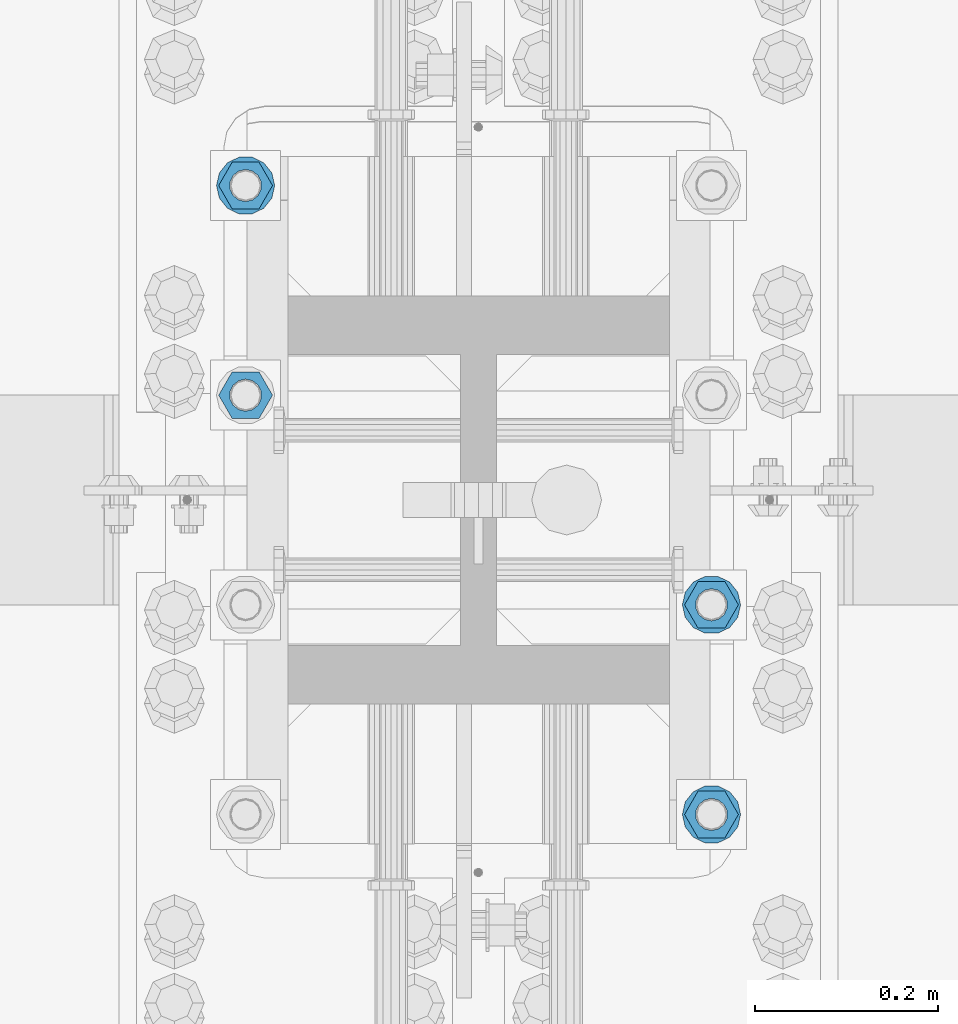
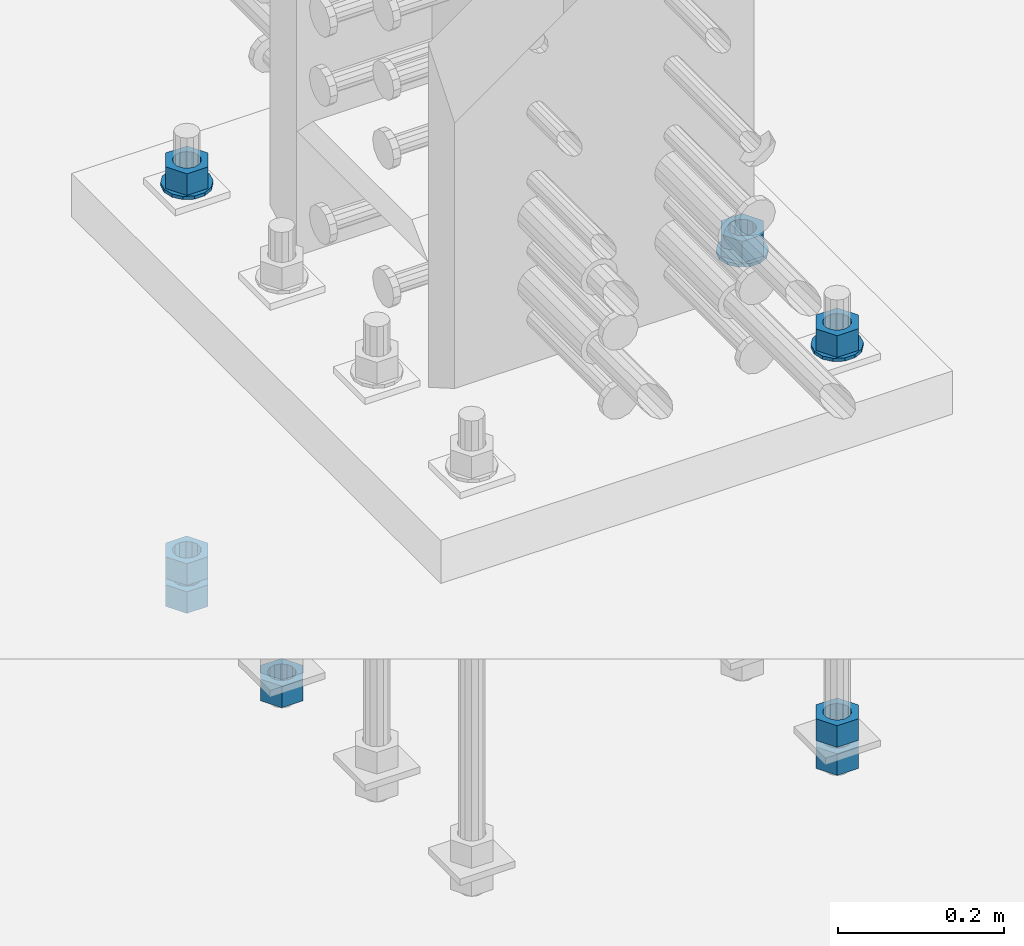
# One storey, part 1011 of 1763: 11 columns, 1 element without a shape of its own.
"""IFC2X3 building model written with IfcOpenShell, lengths in millimetres."""

from ifc_helpers import new_model, si_unit, frame, origin_with_axes, place, context, subcontext, project, spatial, faceted_brep, material, type_object, element, aggregate, save


model = new_model("IFC2X3")

# Units and contexts
model_context = context("Model", 3, precision=1e-05, world=origin_with_axes())
body_context = subcontext(model_context, "Body", "Model", "MODEL_VIEW")
ifc_project = project(units=[si_unit("LENGTHUNIT", "METRE", prefix="MILLI"), si_unit("AREAUNIT", "SQUARE_METRE"), si_unit("VOLUMEUNIT", "CUBIC_METRE"), si_unit("MASSUNIT", "GRAM", prefix="KILO"), si_unit("TIMEUNIT", "SECOND"), si_unit("PLANEANGLEUNIT", "RADIAN"), si_unit("SOLIDANGLEUNIT", "STERADIAN"), si_unit("THERMODYNAMICTEMPERATUREUNIT", "DEGREE_CELSIUS"), si_unit("LUMINOUSINTENSITYUNIT", "LUMEN")], contexts=[model_context])

# Site, building, storey
site_placement = place(None, origin_with_axes())
site = spatial("IfcSite", under=ifc_project, at=site_placement, CompositionType="ELEMENT")
building_placement = place(site_placement, origin_with_axes())
building = spatial("IfcBuilding", under=site, at=building_placement, Name="Undefined", CompositionType="ELEMENT")
storey_placement = place(building_placement, origin_with_axes())
storey = spatial("IfcBuildingStorey", under=building, at=storey_placement, Name="Undefined", CompositionType="ELEMENT", Elevation=0.0)

# Assembly, columns
assembly_placement = place(storey_placement, origin_with_axes())
assembly = element("IfcElementAssembly", 1, at=assembly_placement, inside=storey, Name="TEMPLATE", AssemblyPlace="NOTDEFINED", PredefinedType="RIGID_FRAME")
ifc_material_1 = material(Name="STEEL/A563")
column_type_1 = type_object("IfcColumnType", Name="1-1/4_HEAVY_HEX_NUT", PredefinedType="NOTDEFINED")
column_1_placement = place(assembly_placement, frame((-23773.8372736984, 114.299999999998, 3957.6375), z_axis=(0.0, 1.0, 0.0), x_axis=(0.0, 0.0, -1.0)))
column_1 = element("IfcColumn", 2, at=column_1_placement, type_object=column_type_1, material=ifc_material_1, Name="NUT", ObjectType="1-1/4_HEAVY_HEX_NUT", context=body_context, shape_type="Brep", body=[
    faceted_brep([(0.0, -29.3700008392334, 0.0), (0.0, -14.6800003051758, -25.4300003051758), (31.75, -14.6800003051758, -25.4300003051758), (31.75, -29.3700008392334, 0.0), (0.0, 14.6800003051758, -25.4300003051758), (31.75, 14.6800003051758, -25.4300003051758), (0.0, 29.3700008392334, 0.0), (31.75, 29.3700008392334, 0.0), (0.0, 14.6800003051758, 25.4300003051758), (31.75, 14.6800003051758, 25.4300003051758), (0.0, -14.6800003051758, 25.4300003051758), (31.75, -14.6800003051758, 25.4300003051758), (0.0, 0.0, 17.4599990844727), (0.0, 7.57560968776022, 15.730915608714), (31.75, 7.57560968775942, 15.7309156087145), (31.75, 0.0, 17.4599990844727), (0.0, 13.6507769681037, 10.8861313696252), (31.75, 13.6507769681048, 10.8861313696314), (0.0, 17.0222404541215, 3.88521530314756), (31.75, 17.02224045412, 3.88521530315316), (0.0, 17.0222404541215, -3.88521530314756), (31.75, 17.02224045412, -3.88521530315332), (0.0, 13.6507769681037, -10.8861313696252), (31.75, 13.6507769681048, -10.8861313696316), (0.0, 7.57560968776022, -15.730915608714), (31.75, 7.57560968775942, -15.7309156087146), (0.0, 0.0, -17.4599990844727), (31.75, 0.0, -17.4599990844727), (0.0, -7.57560968776022, -15.730915608714), (31.75, -7.57560968775942, -15.7309156087145), (0.0, -13.6507769681037, -10.8861313696252), (31.75, -13.6507769681048, -10.8861313696314), (0.0, -17.0222404541215, -3.88521530314756), (31.75, -17.02224045412, -3.88521530315316), (0.0, -17.0222404541215, 3.88521530314756), (31.75, -17.02224045412, 3.88521530315332), (0.0, -13.6507769681037, 10.8861313696252), (31.75, -13.6507769681048, 10.8861313696316), (0.0, -7.57560968776022, 15.730915608714), (31.75, -7.57560968775942, 15.7309156087146)], [[[0, 1, 2, 3]], [[1, 4, 5, 2]], [[4, 6, 7, 5]], [[6, 8, 9, 7]], [[8, 10, 11, 9]], [[10, 0, 3, 11]], [[12, 13, 14, 15]], [[13, 16, 17, 14]], [[16, 18, 19, 17]], [[18, 20, 21, 19]], [[20, 22, 23, 21]], [[22, 24, 25, 23]], [[24, 26, 27, 25]], [[26, 28, 29, 27]], [[28, 30, 31, 29]], [[30, 32, 33, 31]], [[32, 34, 35, 33]], [[34, 36, 37, 35]], [[36, 38, 39, 37]], [[38, 12, 15, 39]], [[5, 7, 9, 11, 3, 2], [17, 19, 21, 23, 25, 27, 29, 31, 33, 35, 37, 39, 15, 14]], [[10, 8, 6, 4, 1, 0], [38, 36, 34, 32, 30, 28, 26, 24, 22, 20, 18, 16, 13, 12]]]),
])
column_2_placement = place(assembly_placement, frame((-23773.8372736984, 114.299999999998, 3384.55), z_axis=(0.0, 1.0, 0.0), x_axis=(0.0, 0.0, -1.0)))
column_2 = element("IfcColumn", 3, at=column_2_placement, type_object=column_type_1, material=ifc_material_1, Name="NUT", ObjectType="1-1/4_HEAVY_HEX_NUT", context=body_context, shape_type="Brep", body=[
    faceted_brep([(0.0, -29.3700008392334, 0.0), (0.0, -14.6800003051758, -25.4300003051758), (31.75, -14.6800003051758, -25.4300003051758), (31.75, -29.3700008392334, 0.0), (0.0, 14.6800003051758, -25.4300003051758), (31.75, 14.6800003051758, -25.4300003051758), (0.0, 29.3700008392334, 0.0), (31.75, 29.3700008392334, 0.0), (0.0, 14.6800003051758, 25.4300003051758), (31.75, 14.6800003051758, 25.4300003051758), (0.0, -14.6800003051758, 25.4300003051758), (31.75, -14.6800003051758, 25.4300003051758), (0.0, 0.0, 17.4599990844727), (0.0, 7.57560968776022, 15.730915608714), (31.75, 7.57560968775942, 15.7309156087145), (31.75, 0.0, 17.4599990844727), (0.0, 13.6507769681037, 10.8861313696252), (31.75, 13.6507769681048, 10.8861313696314), (0.0, 17.0222404541215, 3.88521530314756), (31.75, 17.02224045412, 3.88521530315316), (0.0, 17.0222404541215, -3.88521530314756), (31.75, 17.02224045412, -3.88521530315332), (0.0, 13.6507769681037, -10.8861313696252), (31.75, 13.6507769681048, -10.8861313696316), (0.0, 7.57560968776022, -15.730915608714), (31.75, 7.57560968775942, -15.7309156087146), (0.0, 0.0, -17.4599990844727), (31.75, 0.0, -17.4599990844727), (0.0, -7.57560968776022, -15.730915608714), (31.75, -7.57560968775942, -15.7309156087145), (0.0, -13.6507769681037, -10.8861313696252), (31.75, -13.6507769681048, -10.8861313696314), (0.0, -17.0222404541215, -3.88521530314756), (31.75, -17.02224045412, -3.88521530315316), (0.0, -17.0222404541215, 3.88521530314756), (31.75, -17.02224045412, 3.88521530315332), (0.0, -13.6507769681037, 10.8861313696252), (31.75, -13.6507769681048, 10.8861313696316), (0.0, -7.57560968776022, 15.730915608714), (31.75, -7.57560968775942, 15.7309156087146)], [[[0, 1, 2, 3]], [[1, 4, 5, 2]], [[4, 6, 7, 5]], [[6, 8, 9, 7]], [[8, 10, 11, 9]], [[10, 0, 3, 11]], [[12, 13, 14, 15]], [[13, 16, 17, 14]], [[16, 18, 19, 17]], [[18, 20, 21, 19]], [[20, 22, 23, 21]], [[22, 24, 25, 23]], [[24, 26, 27, 25]], [[26, 28, 29, 27]], [[28, 30, 31, 29]], [[30, 32, 33, 31]], [[32, 34, 35, 33]], [[34, 36, 37, 35]], [[36, 38, 39, 37]], [[38, 12, 15, 39]], [[5, 7, 9, 11, 3, 2], [17, 19, 21, 23, 25, 27, 29, 31, 33, 35, 37, 39, 15, 14]], [[10, 8, 6, 4, 1, 0], [38, 36, 34, 32, 30, 28, 26, 24, 22, 20, 18, 16, 13, 12]]]),
])
column_3_placement = place(assembly_placement, frame((-23773.8372736984, 114.299999999998, 3343.275), z_axis=(0.0, 1.0, 0.0), x_axis=(0.0, 0.0, -1.0)))
column_3 = element("IfcColumn", 4, at=column_3_placement, type_object=column_type_1, material=ifc_material_1, Name="NUT", ObjectType="1-1/4_HEAVY_HEX_NUT", context=body_context, shape_type="Brep", body=[
    faceted_brep([(0.0, -29.3700008392334, 0.0), (0.0, -14.6800003051758, -25.4300003051758), (31.75, -14.6800003051758, -25.4300003051758), (31.75, -29.3700008392334, 0.0), (0.0, 14.6800003051758, -25.4300003051758), (31.75, 14.6800003051758, -25.4300003051758), (0.0, 29.3700008392334, 0.0), (31.75, 29.3700008392334, 0.0), (0.0, 14.6800003051758, 25.4300003051758), (31.75, 14.6800003051758, 25.4300003051758), (0.0, -14.6800003051758, 25.4300003051758), (31.75, -14.6800003051758, 25.4300003051758), (0.0, 0.0, 17.4599990844727), (0.0, 7.57560968776022, 15.730915608714), (31.75, 7.57560968775942, 15.7309156087145), (31.75, 0.0, 17.4599990844727), (0.0, 13.6507769681037, 10.8861313696252), (31.75, 13.6507769681048, 10.8861313696314), (0.0, 17.0222404541215, 3.88521530314756), (31.75, 17.02224045412, 3.88521530315316), (0.0, 17.0222404541215, -3.88521530314756), (31.75, 17.02224045412, -3.88521530315332), (0.0, 13.6507769681037, -10.8861313696252), (31.75, 13.6507769681048, -10.8861313696316), (0.0, 7.57560968776022, -15.730915608714), (31.75, 7.57560968775942, -15.7309156087146), (0.0, 0.0, -17.4599990844727), (31.75, 0.0, -17.4599990844727), (0.0, -7.57560968776022, -15.730915608714), (31.75, -7.57560968775942, -15.7309156087145), (0.0, -13.6507769681037, -10.8861313696252), (31.75, -13.6507769681048, -10.8861313696314), (0.0, -17.0222404541215, -3.88521530314756), (31.75, -17.02224045412, -3.88521530315316), (0.0, -17.0222404541215, 3.88521530314756), (31.75, -17.02224045412, 3.88521530315332), (0.0, -13.6507769681037, 10.8861313696252), (31.75, -13.6507769681048, 10.8861313696316), (0.0, -7.57560968776022, 15.730915608714), (31.75, -7.57560968775942, 15.7309156087146)], [[[0, 1, 2, 3]], [[1, 4, 5, 2]], [[4, 6, 7, 5]], [[6, 8, 9, 7]], [[8, 10, 11, 9]], [[10, 0, 3, 11]], [[12, 13, 14, 15]], [[13, 16, 17, 14]], [[16, 18, 19, 17]], [[18, 20, 21, 19]], [[20, 22, 23, 21]], [[22, 24, 25, 23]], [[24, 26, 27, 25]], [[26, 28, 29, 27]], [[28, 30, 31, 29]], [[30, 32, 33, 31]], [[32, 34, 35, 33]], [[34, 36, 37, 35]], [[36, 38, 39, 37]], [[38, 12, 15, 39]], [[5, 7, 9, 11, 3, 2], [17, 19, 21, 23, 25, 27, 29, 31, 33, 35, 37, 39, 15, 14]], [[10, 8, 6, 4, 1, 0], [38, 36, 34, 32, 30, 28, 26, 24, 22, 20, 18, 16, 13, 12]]]),
])
column_4_placement = place(assembly_placement, frame((-23773.8372736984, 342.899999999998, 3957.6375), z_axis=(0.0, 1.0, 0.0), x_axis=(0.0, 0.0, -1.0)))
column_4 = element("IfcColumn", 5, at=column_4_placement, type_object=column_type_1, material=ifc_material_1, Name="NUT", ObjectType="1-1/4_HEAVY_HEX_NUT", context=body_context, shape_type="Brep", body=[
    faceted_brep([(0.0, -29.3700008392334, 0.0), (0.0, -14.6800003051758, -25.4300003051758), (31.75, -14.6800003051758, -25.4300003051758), (31.75, -29.3700008392334, 0.0), (0.0, 14.6800003051758, -25.4300003051758), (31.75, 14.6800003051758, -25.4300003051758), (0.0, 29.3700008392334, 0.0), (31.75, 29.3700008392334, 0.0), (0.0, 14.6800003051758, 25.4300003051758), (31.75, 14.6800003051758, 25.4300003051758), (0.0, -14.6800003051758, 25.4300003051758), (31.75, -14.6800003051758, 25.4300003051758), (0.0, 0.0, 17.4599990844727), (0.0, 7.57560968776022, 15.730915608714), (31.75, 7.57560968775942, 15.7309156087145), (31.75, 0.0, 17.4599990844727), (0.0, 13.6507769681037, 10.8861313696252), (31.75, 13.6507769681048, 10.8861313696314), (0.0, 17.0222404541215, 3.88521530314756), (31.75, 17.02224045412, 3.88521530315316), (0.0, 17.0222404541215, -3.88521530314756), (31.75, 17.02224045412, -3.88521530315332), (0.0, 13.6507769681037, -10.8861313696252), (31.75, 13.6507769681048, -10.8861313696316), (0.0, 7.57560968776022, -15.730915608714), (31.75, 7.57560968775942, -15.7309156087146), (0.0, 0.0, -17.4599990844727), (31.75, 0.0, -17.4599990844727), (0.0, -7.57560968776022, -15.730915608714), (31.75, -7.57560968775942, -15.7309156087145), (0.0, -13.6507769681037, -10.8861313696252), (31.75, -13.6507769681048, -10.8861313696314), (0.0, -17.0222404541215, -3.88521530314756), (31.75, -17.02224045412, -3.88521530315316), (0.0, -17.0222404541215, 3.88521530314756), (31.75, -17.02224045412, 3.88521530315332), (0.0, -13.6507769681037, 10.8861313696252), (31.75, -13.6507769681048, 10.8861313696316), (0.0, -7.57560968776022, 15.730915608714), (31.75, -7.57560968775942, 15.7309156087146)], [[[0, 1, 2, 3]], [[1, 4, 5, 2]], [[4, 6, 7, 5]], [[6, 8, 9, 7]], [[8, 10, 11, 9]], [[10, 0, 3, 11]], [[12, 13, 14, 15]], [[13, 16, 17, 14]], [[16, 18, 19, 17]], [[18, 20, 21, 19]], [[20, 22, 23, 21]], [[22, 24, 25, 23]], [[24, 26, 27, 25]], [[26, 28, 29, 27]], [[28, 30, 31, 29]], [[30, 32, 33, 31]], [[32, 34, 35, 33]], [[34, 36, 37, 35]], [[36, 38, 39, 37]], [[38, 12, 15, 39]], [[5, 7, 9, 11, 3, 2], [17, 19, 21, 23, 25, 27, 29, 31, 33, 35, 37, 39, 15, 14]], [[10, 8, 6, 4, 1, 0], [38, 36, 34, 32, 30, 28, 26, 24, 22, 20, 18, 16, 13, 12]]]),
])
column_5_placement = place(assembly_placement, frame((-24281.8372736984, 571.499999999998, 3343.275), z_axis=(0.0, -1.0, 0.0), x_axis=(0.0, 0.0, -1.0)))
column_5 = element("IfcColumn", 6, at=column_5_placement, type_object=column_type_1, material=ifc_material_1, Name="NUT", ObjectType="1-1/4_HEAVY_HEX_NUT", context=body_context, shape_type="Brep", body=[
    faceted_brep([(0.0, -29.3700008392334, 0.0), (0.0, -14.6800003051758, -25.4300003051758), (31.75, -14.6800003051758, -25.4300003051758), (31.75, -29.3700008392334, 0.0), (0.0, 14.6800003051758, -25.4300003051758), (31.75, 14.6800003051758, -25.4300003051758), (0.0, 29.3700008392334, 0.0), (31.75, 29.3700008392334, 0.0), (0.0, 14.6800003051758, 25.4300003051758), (31.75, 14.6800003051758, 25.4300003051758), (0.0, -14.6800003051758, 25.4300003051758), (31.75, -14.6800003051758, 25.4300003051758), (0.0, 0.0, 17.4599990844727), (0.0, 7.57560968776022, 15.730915608714), (31.75, 7.57560968775942, 15.7309156087145), (31.75, 0.0, 17.4599990844727), (0.0, 13.6507769681037, 10.8861313696252), (31.75, 13.6507769681048, 10.8861313696314), (0.0, 17.0222404541215, 3.88521530314756), (31.75, 17.02224045412, 3.88521530315316), (0.0, 17.0222404541215, -3.88521530314756), (31.75, 17.02224045412, -3.88521530315332), (0.0, 13.6507769681037, -10.8861313696252), (31.75, 13.6507769681048, -10.8861313696316), (0.0, 7.57560968776022, -15.730915608714), (31.75, 7.57560968775942, -15.7309156087146), (0.0, 0.0, -17.4599990844727), (31.75, 0.0, -17.4599990844727), (0.0, -7.57560968776022, -15.730915608714), (31.75, -7.57560968775942, -15.7309156087145), (0.0, -13.6507769681037, -10.8861313696252), (31.75, -13.6507769681048, -10.8861313696314), (0.0, -17.0222404541215, -3.88521530314756), (31.75, -17.02224045412, -3.88521530315316), (0.0, -17.0222404541215, 3.88521530314756), (31.75, -17.02224045412, 3.88521530315332), (0.0, -13.6507769681037, 10.8861313696252), (31.75, -13.6507769681048, 10.8861313696316), (0.0, -7.57560968776022, 15.730915608714), (31.75, -7.57560968775942, 15.7309156087146)], [[[0, 1, 2, 3]], [[1, 4, 5, 2]], [[4, 6, 7, 5]], [[6, 8, 9, 7]], [[8, 10, 11, 9]], [[10, 0, 3, 11]], [[12, 13, 14, 15]], [[13, 16, 17, 14]], [[16, 18, 19, 17]], [[18, 20, 21, 19]], [[20, 22, 23, 21]], [[22, 24, 25, 23]], [[24, 26, 27, 25]], [[26, 28, 29, 27]], [[28, 30, 31, 29]], [[30, 32, 33, 31]], [[32, 34, 35, 33]], [[34, 36, 37, 35]], [[36, 38, 39, 37]], [[38, 12, 15, 39]], [[5, 7, 9, 11, 3, 2], [17, 19, 21, 23, 25, 27, 29, 31, 33, 35, 37, 39, 15, 14]], [[10, 8, 6, 4, 1, 0], [38, 36, 34, 32, 30, 28, 26, 24, 22, 20, 18, 16, 13, 12]]]),
])
column_6_placement = place(assembly_placement, frame((-24281.8372736984, 800.099999999998, 3957.6375), z_axis=(0.0, -1.0, 0.0), x_axis=(0.0, 0.0, -1.0)))
column_6 = element("IfcColumn", 7, at=column_6_placement, type_object=column_type_1, material=ifc_material_1, Name="NUT", ObjectType="1-1/4_HEAVY_HEX_NUT", context=body_context, shape_type="Brep", body=[
    faceted_brep([(0.0, -29.3700008392334, 0.0), (0.0, -14.6800003051758, -25.4300003051758), (31.75, -14.6800003051758, -25.4300003051758), (31.75, -29.3700008392334, 0.0), (0.0, 14.6800003051758, -25.4300003051758), (31.75, 14.6800003051758, -25.4300003051758), (0.0, 29.3700008392334, 0.0), (31.75, 29.3700008392334, 0.0), (0.0, 14.6800003051758, 25.4300003051758), (31.75, 14.6800003051758, 25.4300003051758), (0.0, -14.6800003051758, 25.4300003051758), (31.75, -14.6800003051758, 25.4300003051758), (0.0, 0.0, 17.4599990844727), (0.0, 7.57560968776022, 15.730915608714), (31.75, 7.57560968775942, 15.7309156087145), (31.75, 0.0, 17.4599990844727), (0.0, 13.6507769681037, 10.8861313696252), (31.75, 13.6507769681048, 10.8861313696314), (0.0, 17.0222404541215, 3.88521530314756), (31.75, 17.02224045412, 3.88521530315316), (0.0, 17.0222404541215, -3.88521530314756), (31.75, 17.02224045412, -3.88521530315332), (0.0, 13.6507769681037, -10.8861313696252), (31.75, 13.6507769681048, -10.8861313696316), (0.0, 7.57560968776022, -15.730915608714), (31.75, 7.57560968775942, -15.7309156087146), (0.0, 0.0, -17.4599990844727), (31.75, 0.0, -17.4599990844727), (0.0, -7.57560968776022, -15.730915608714), (31.75, -7.57560968775942, -15.7309156087145), (0.0, -13.6507769681037, -10.8861313696252), (31.75, -13.6507769681048, -10.8861313696314), (0.0, -17.0222404541215, -3.88521530314756), (31.75, -17.02224045412, -3.88521530315316), (0.0, -17.0222404541215, 3.88521530314756), (31.75, -17.02224045412, 3.88521530315332), (0.0, -13.6507769681037, 10.8861313696252), (31.75, -13.6507769681048, 10.8861313696316), (0.0, -7.57560968776022, 15.730915608714), (31.75, -7.57560968775942, 15.7309156087146)], [[[0, 1, 2, 3]], [[1, 4, 5, 2]], [[4, 6, 7, 5]], [[6, 8, 9, 7]], [[8, 10, 11, 9]], [[10, 0, 3, 11]], [[12, 13, 14, 15]], [[13, 16, 17, 14]], [[16, 18, 19, 17]], [[18, 20, 21, 19]], [[20, 22, 23, 21]], [[22, 24, 25, 23]], [[24, 26, 27, 25]], [[26, 28, 29, 27]], [[28, 30, 31, 29]], [[30, 32, 33, 31]], [[32, 34, 35, 33]], [[34, 36, 37, 35]], [[36, 38, 39, 37]], [[38, 12, 15, 39]], [[5, 7, 9, 11, 3, 2], [17, 19, 21, 23, 25, 27, 29, 31, 33, 35, 37, 39, 15, 14]], [[10, 8, 6, 4, 1, 0], [38, 36, 34, 32, 30, 28, 26, 24, 22, 20, 18, 16, 13, 12]]]),
])
column_7_placement = place(assembly_placement, frame((-24281.8372736984, 800.099999999998, 3384.55), z_axis=(0.0, -1.0, 0.0), x_axis=(0.0, 0.0, -1.0)))
column_7 = element("IfcColumn", 8, at=column_7_placement, type_object=column_type_1, material=ifc_material_1, Name="NUT", ObjectType="1-1/4_HEAVY_HEX_NUT", context=body_context, shape_type="Brep", body=[
    faceted_brep([(0.0, -29.3700008392334, 0.0), (0.0, -14.6800003051758, -25.4300003051758), (31.75, -14.6800003051758, -25.4300003051758), (31.75, -29.3700008392334, 0.0), (0.0, 14.6800003051758, -25.4300003051758), (31.75, 14.6800003051758, -25.4300003051758), (0.0, 29.3700008392334, 0.0), (31.75, 29.3700008392334, 0.0), (0.0, 14.6800003051758, 25.4300003051758), (31.75, 14.6800003051758, 25.4300003051758), (0.0, -14.6800003051758, 25.4300003051758), (31.75, -14.6800003051758, 25.4300003051758), (0.0, 0.0, 17.4599990844727), (0.0, 7.57560968776022, 15.730915608714), (31.75, 7.57560968775942, 15.7309156087145), (31.75, 0.0, 17.4599990844727), (0.0, 13.6507769681037, 10.8861313696252), (31.75, 13.6507769681048, 10.8861313696314), (0.0, 17.0222404541215, 3.88521530314756), (31.75, 17.02224045412, 3.88521530315316), (0.0, 17.0222404541215, -3.88521530314756), (31.75, 17.02224045412, -3.88521530315332), (0.0, 13.6507769681037, -10.8861313696252), (31.75, 13.6507769681048, -10.8861313696316), (0.0, 7.57560968776022, -15.730915608714), (31.75, 7.57560968775942, -15.7309156087146), (0.0, 0.0, -17.4599990844727), (31.75, 0.0, -17.4599990844727), (0.0, -7.57560968776022, -15.730915608714), (31.75, -7.57560968775942, -15.7309156087145), (0.0, -13.6507769681037, -10.8861313696252), (31.75, -13.6507769681048, -10.8861313696314), (0.0, -17.0222404541215, -3.88521530314756), (31.75, -17.02224045412, -3.88521530315316), (0.0, -17.0222404541215, 3.88521530314756), (31.75, -17.02224045412, 3.88521530315332), (0.0, -13.6507769681037, 10.8861313696252), (31.75, -13.6507769681048, 10.8861313696316), (0.0, -7.57560968776022, 15.730915608714), (31.75, -7.57560968775942, 15.7309156087146)], [[[0, 1, 2, 3]], [[1, 4, 5, 2]], [[4, 6, 7, 5]], [[6, 8, 9, 7]], [[8, 10, 11, 9]], [[10, 0, 3, 11]], [[12, 13, 14, 15]], [[13, 16, 17, 14]], [[16, 18, 19, 17]], [[18, 20, 21, 19]], [[20, 22, 23, 21]], [[22, 24, 25, 23]], [[24, 26, 27, 25]], [[26, 28, 29, 27]], [[28, 30, 31, 29]], [[30, 32, 33, 31]], [[32, 34, 35, 33]], [[34, 36, 37, 35]], [[36, 38, 39, 37]], [[38, 12, 15, 39]], [[5, 7, 9, 11, 3, 2], [17, 19, 21, 23, 25, 27, 29, 31, 33, 35, 37, 39, 15, 14]], [[10, 8, 6, 4, 1, 0], [38, 36, 34, 32, 30, 28, 26, 24, 22, 20, 18, 16, 13, 12]]]),
])
column_8_placement = place(assembly_placement, frame((-24281.8372736984, 800.099999999998, 3343.275), z_axis=(0.0, -1.0, 0.0), x_axis=(0.0, 0.0, -1.0)))
column_8 = element("IfcColumn", 9, at=column_8_placement, type_object=column_type_1, material=ifc_material_1, Name="NUT", ObjectType="1-1/4_HEAVY_HEX_NUT", context=body_context, shape_type="Brep", body=[
    faceted_brep([(0.0, -29.3700008392334, 0.0), (0.0, -14.6800003051758, -25.4300003051758), (31.75, -14.6800003051758, -25.4300003051758), (31.75, -29.3700008392334, 0.0), (0.0, 14.6800003051758, -25.4300003051758), (31.75, 14.6800003051758, -25.4300003051758), (0.0, 29.3700008392334, 0.0), (31.75, 29.3700008392334, 0.0), (0.0, 14.6800003051758, 25.4300003051758), (31.75, 14.6800003051758, 25.4300003051758), (0.0, -14.6800003051758, 25.4300003051758), (31.75, -14.6800003051758, 25.4300003051758), (0.0, 0.0, 17.4599990844727), (0.0, 7.57560968776022, 15.730915608714), (31.75, 7.57560968775942, 15.7309156087145), (31.75, 0.0, 17.4599990844727), (0.0, 13.6507769681037, 10.8861313696252), (31.75, 13.6507769681048, 10.8861313696314), (0.0, 17.0222404541215, 3.88521530314756), (31.75, 17.02224045412, 3.88521530315316), (0.0, 17.0222404541215, -3.88521530314756), (31.75, 17.02224045412, -3.88521530315332), (0.0, 13.6507769681037, -10.8861313696252), (31.75, 13.6507769681048, -10.8861313696316), (0.0, 7.57560968776022, -15.730915608714), (31.75, 7.57560968775942, -15.7309156087146), (0.0, 0.0, -17.4599990844727), (31.75, 0.0, -17.4599990844727), (0.0, -7.57560968776022, -15.730915608714), (31.75, -7.57560968775942, -15.7309156087145), (0.0, -13.6507769681037, -10.8861313696252), (31.75, -13.6507769681048, -10.8861313696314), (0.0, -17.0222404541215, -3.88521530314756), (31.75, -17.02224045412, -3.88521530315316), (0.0, -17.0222404541215, 3.88521530314756), (31.75, -17.02224045412, 3.88521530315332), (0.0, -13.6507769681037, 10.8861313696252), (31.75, -13.6507769681048, 10.8861313696316), (0.0, -7.57560968776022, 15.730915608714), (31.75, -7.57560968775942, 15.7309156087146)], [[[0, 1, 2, 3]], [[1, 4, 5, 2]], [[4, 6, 7, 5]], [[6, 8, 9, 7]], [[8, 10, 11, 9]], [[10, 0, 3, 11]], [[12, 13, 14, 15]], [[13, 16, 17, 14]], [[16, 18, 19, 17]], [[18, 20, 21, 19]], [[20, 22, 23, 21]], [[22, 24, 25, 23]], [[24, 26, 27, 25]], [[26, 28, 29, 27]], [[28, 30, 31, 29]], [[30, 32, 33, 31]], [[32, 34, 35, 33]], [[34, 36, 37, 35]], [[36, 38, 39, 37]], [[38, 12, 15, 39]], [[5, 7, 9, 11, 3, 2], [17, 19, 21, 23, 25, 27, 29, 31, 33, 35, 37, 39, 15, 14]], [[10, 8, 6, 4, 1, 0], [38, 36, 34, 32, 30, 28, 26, 24, 22, 20, 18, 16, 13, 12]]]),
])
ifc_material_2 = material(Name="STEEL/F436")
column_type_2 = type_object("IfcColumnType", Name="1-1/4_WASHER", PredefinedType="NOTDEFINED")
column_9_placement = place(assembly_placement, frame((-23773.8372736984, 114.299999999998, 3925.8875), z_axis=(0.0, 1.0, 0.0), x_axis=(0.0, 0.0, -1.0)))
column_9 = element("IfcColumn", 10, at=column_9_placement, type_object=column_type_2, material=ifc_material_2, Name="WASHER", ObjectType="1-1/4_WASHER", context=body_context, shape_type="Brep", body=[
    faceted_brep([(-4.54747350886464e-13, -31.7499999999964, 0.0), (0.0, -28.6057615559002, -13.7758087169827), (4.76249999999982, -28.6057615559002, -13.7758087169827), (4.76249999999982, -31.75, 0.0), (0.0, -19.795801209013, -24.8231495683602), (4.76249999999982, -19.795801209013, -24.8231495683602), (0.0, -7.06503965311276, -30.9539612117732), (4.76249999999982, -7.06503965311276, -30.9539612117732), (0.0, 7.06503965311276, -30.9539612117732), (4.76249999999982, 7.06503965311276, -30.9539612117732), (0.0, 19.7958012090166, -24.8231495683602), (4.76249999999982, 19.7958012090166, -24.8231495683602), (0.0, 28.6057615559039, -13.7758087169827), (4.76249999999982, 28.6057615559039, -13.7758087169827), (-5.91171556152403e-12, 31.7499999999891, 0.0), (4.76249999999982, 31.75, 0.0), (0.0, 28.6057615559002, 13.7758087169827), (4.76249999999982, 28.6057615559002, 13.7758087169827), (0.0, 19.795801209013, 24.8231495683602), (4.76249999999982, 19.795801209013, 24.8231495683602), (0.0, 7.06503965311276, 30.9539612117731), (4.76249999999982, 7.06503965311276, 30.9539612117731), (0.0, -7.06503965311276, 30.9539612117731), (4.76249999999982, -7.06503965311276, 30.9539612117731), (0.0, -19.7958012090166, 24.8231495683602), (4.76249999999982, -19.7958012090166, 24.8231495683602), (0.0, -28.6057615559039, 13.7758087169827), (4.76249999999982, -28.6057615559039, 13.7758087169827), (0.0, 0.0, 17.4599990844727), (0.0, 7.57560968776022, 15.730915608714), (4.76249999999982, 7.57560968775942, 15.7309156087145), (4.76249999999982, 0.0, 17.4599990844727), (0.0, 13.6507769681037, 10.8861313696252), (4.76249999999982, 13.6507769681048, 10.8861313696314), (0.0, 17.0222404541215, 3.88521530314756), (4.76249999999982, 17.02224045412, 3.88521530315316), (0.0, 17.0222404541215, -3.88521530314756), (4.76249999999982, 17.02224045412, -3.88521530315332), (0.0, 13.6507769681037, -10.8861313696252), (4.76249999999982, 13.6507769681048, -10.8861313696316), (0.0, 7.57560968776022, -15.730915608714), (4.76249999999982, 7.57560968775942, -15.7309156087146), (0.0, 0.0, -17.4599990844727), (4.76249999999982, 0.0, -17.4599990844727), (0.0, -7.57560968776022, -15.730915608714), (4.76249999999982, -7.57560968775942, -15.7309156087145), (0.0, -13.6507769681037, -10.8861313696252), (4.76249999999982, -13.6507769681048, -10.8861313696314), (0.0, -17.0222404541215, -3.88521530314756), (4.76249999999982, -17.02224045412, -3.88521530315316), (0.0, -17.0222404541215, 3.88521530314756), (4.76249999999982, -17.02224045412, 3.88521530315332), (0.0, -13.6507769681037, 10.8861313696252), (4.76249999999982, -13.6507769681048, 10.8861313696316), (0.0, -7.57560968776022, 15.730915608714), (4.76249999999982, -7.57560968775942, 15.7309156087146)], [[[0, 1, 2, 3]], [[1, 4, 5, 2]], [[4, 6, 7, 5]], [[6, 8, 9, 7]], [[8, 10, 11, 9]], [[10, 12, 13, 11]], [[12, 14, 15, 13]], [[14, 16, 17, 15]], [[16, 18, 19, 17]], [[18, 20, 21, 19]], [[20, 22, 23, 21]], [[22, 24, 25, 23]], [[24, 26, 27, 25]], [[26, 0, 3, 27]], [[28, 29, 30, 31]], [[29, 32, 33, 30]], [[32, 34, 35, 33]], [[34, 36, 37, 35]], [[36, 38, 39, 37]], [[38, 40, 41, 39]], [[40, 42, 43, 41]], [[42, 44, 45, 43]], [[44, 46, 47, 45]], [[46, 48, 49, 47]], [[48, 50, 51, 49]], [[50, 52, 53, 51]], [[52, 54, 55, 53]], [[54, 28, 31, 55]], [[5, 7, 9, 11, 13, 15, 17, 19, 21, 23, 25, 27, 3, 2], [33, 35, 37, 39, 41, 43, 45, 47, 49, 51, 53, 55, 31, 30]], [[26, 24, 22, 20, 18, 16, 14, 12, 10, 8, 6, 4, 1, 0], [54, 52, 50, 48, 46, 44, 42, 40, 38, 36, 34, 32, 29, 28]]]),
])
column_10_placement = place(assembly_placement, frame((-23773.8372736984, 342.899999999998, 3925.8875), z_axis=(0.0, 1.0, 0.0), x_axis=(0.0, 0.0, -1.0)))
column_10 = element("IfcColumn", 11, at=column_10_placement, type_object=column_type_2, material=ifc_material_2, Name="WASHER", ObjectType="1-1/4_WASHER", context=body_context, shape_type="Brep", body=[
    faceted_brep([(-4.54747350886464e-13, -31.7499999999964, 0.0), (0.0, -28.6057615559002, -13.7758087169827), (4.76249999999982, -28.6057615559002, -13.7758087169827), (4.76249999999982, -31.75, 0.0), (0.0, -19.795801209013, -24.8231495683602), (4.76249999999982, -19.795801209013, -24.8231495683602), (0.0, -7.06503965311276, -30.9539612117732), (4.76249999999982, -7.06503965311276, -30.9539612117732), (0.0, 7.06503965311276, -30.9539612117732), (4.76249999999982, 7.06503965311276, -30.9539612117732), (0.0, 19.7958012090166, -24.8231495683602), (4.76249999999982, 19.7958012090166, -24.8231495683602), (0.0, 28.6057615559039, -13.7758087169827), (4.76249999999982, 28.6057615559039, -13.7758087169827), (-5.91171556152403e-12, 31.7499999999891, 0.0), (4.76249999999982, 31.75, 0.0), (0.0, 28.6057615559002, 13.7758087169827), (4.76249999999982, 28.6057615559002, 13.7758087169827), (0.0, 19.795801209013, 24.8231495683602), (4.76249999999982, 19.795801209013, 24.8231495683602), (0.0, 7.06503965311276, 30.9539612117731), (4.76249999999982, 7.06503965311276, 30.9539612117731), (0.0, -7.06503965311276, 30.9539612117731), (4.76249999999982, -7.06503965311276, 30.9539612117731), (0.0, -19.7958012090166, 24.8231495683602), (4.76249999999982, -19.7958012090166, 24.8231495683602), (0.0, -28.6057615559039, 13.7758087169827), (4.76249999999982, -28.6057615559039, 13.7758087169827), (0.0, 0.0, 17.4599990844727), (0.0, 7.57560968776022, 15.730915608714), (4.76249999999982, 7.57560968775942, 15.7309156087145), (4.76249999999982, 0.0, 17.4599990844727), (0.0, 13.6507769681037, 10.8861313696252), (4.76249999999982, 13.6507769681048, 10.8861313696314), (0.0, 17.0222404541215, 3.88521530314756), (4.76249999999982, 17.02224045412, 3.88521530315316), (0.0, 17.0222404541215, -3.88521530314756), (4.76249999999982, 17.02224045412, -3.88521530315332), (0.0, 13.6507769681037, -10.8861313696252), (4.76249999999982, 13.6507769681048, -10.8861313696316), (0.0, 7.57560968776022, -15.730915608714), (4.76249999999982, 7.57560968775942, -15.7309156087146), (0.0, 0.0, -17.4599990844727), (4.76249999999982, 0.0, -17.4599990844727), (0.0, -7.57560968776022, -15.730915608714), (4.76249999999982, -7.57560968775942, -15.7309156087145), (0.0, -13.6507769681037, -10.8861313696252), (4.76249999999982, -13.6507769681048, -10.8861313696314), (0.0, -17.0222404541215, -3.88521530314756), (4.76249999999982, -17.02224045412, -3.88521530315316), (0.0, -17.0222404541215, 3.88521530314756), (4.76249999999982, -17.02224045412, 3.88521530315332), (0.0, -13.6507769681037, 10.8861313696252), (4.76249999999982, -13.6507769681048, 10.8861313696316), (0.0, -7.57560968776022, 15.730915608714), (4.76249999999982, -7.57560968775942, 15.7309156087146)], [[[0, 1, 2, 3]], [[1, 4, 5, 2]], [[4, 6, 7, 5]], [[6, 8, 9, 7]], [[8, 10, 11, 9]], [[10, 12, 13, 11]], [[12, 14, 15, 13]], [[14, 16, 17, 15]], [[16, 18, 19, 17]], [[18, 20, 21, 19]], [[20, 22, 23, 21]], [[22, 24, 25, 23]], [[24, 26, 27, 25]], [[26, 0, 3, 27]], [[28, 29, 30, 31]], [[29, 32, 33, 30]], [[32, 34, 35, 33]], [[34, 36, 37, 35]], [[36, 38, 39, 37]], [[38, 40, 41, 39]], [[40, 42, 43, 41]], [[42, 44, 45, 43]], [[44, 46, 47, 45]], [[46, 48, 49, 47]], [[48, 50, 51, 49]], [[50, 52, 53, 51]], [[52, 54, 55, 53]], [[54, 28, 31, 55]], [[5, 7, 9, 11, 13, 15, 17, 19, 21, 23, 25, 27, 3, 2], [33, 35, 37, 39, 41, 43, 45, 47, 49, 51, 53, 55, 31, 30]], [[26, 24, 22, 20, 18, 16, 14, 12, 10, 8, 6, 4, 1, 0], [54, 52, 50, 48, 46, 44, 42, 40, 38, 36, 34, 32, 29, 28]]]),
])
column_11_placement = place(assembly_placement, frame((-24281.8372736984, 800.099999999998, 3925.8875), z_axis=(0.0, -1.0, 0.0), x_axis=(0.0, 0.0, -1.0)))
column_11 = element("IfcColumn", 12, at=column_11_placement, type_object=column_type_2, material=ifc_material_2, Name="WASHER", ObjectType="1-1/4_WASHER", context=body_context, shape_type="Brep", body=[
    faceted_brep([(-4.54747350886464e-13, -31.7499999999964, 0.0), (0.0, -28.6057615559002, -13.7758087169827), (4.76249999999982, -28.6057615559002, -13.7758087169827), (4.76249999999982, -31.75, 0.0), (0.0, -19.795801209013, -24.8231495683602), (4.76249999999982, -19.795801209013, -24.8231495683602), (0.0, -7.06503965311276, -30.9539612117732), (4.76249999999982, -7.06503965311276, -30.9539612117732), (0.0, 7.06503965311276, -30.9539612117732), (4.76249999999982, 7.06503965311276, -30.9539612117732), (0.0, 19.7958012090166, -24.8231495683602), (4.76249999999982, 19.7958012090166, -24.8231495683602), (0.0, 28.6057615559039, -13.7758087169827), (4.76249999999982, 28.6057615559039, -13.7758087169827), (-5.91171556152403e-12, 31.7499999999891, 0.0), (4.76249999999982, 31.75, 0.0), (0.0, 28.6057615559002, 13.7758087169827), (4.76249999999982, 28.6057615559002, 13.7758087169827), (0.0, 19.795801209013, 24.8231495683602), (4.76249999999982, 19.795801209013, 24.8231495683602), (0.0, 7.06503965311276, 30.9539612117731), (4.76249999999982, 7.06503965311276, 30.9539612117731), (0.0, -7.06503965311276, 30.9539612117731), (4.76249999999982, -7.06503965311276, 30.9539612117731), (0.0, -19.7958012090166, 24.8231495683602), (4.76249999999982, -19.7958012090166, 24.8231495683602), (0.0, -28.6057615559039, 13.7758087169827), (4.76249999999982, -28.6057615559039, 13.7758087169827), (0.0, 0.0, 17.4599990844727), (0.0, 7.57560968776022, 15.730915608714), (4.76249999999982, 7.57560968775942, 15.7309156087145), (4.76249999999982, 0.0, 17.4599990844727), (0.0, 13.6507769681037, 10.8861313696252), (4.76249999999982, 13.6507769681048, 10.8861313696314), (0.0, 17.0222404541215, 3.88521530314756), (4.76249999999982, 17.02224045412, 3.88521530315316), (0.0, 17.0222404541215, -3.88521530314756), (4.76249999999982, 17.02224045412, -3.88521530315332), (0.0, 13.6507769681037, -10.8861313696252), (4.76249999999982, 13.6507769681048, -10.8861313696316), (0.0, 7.57560968776022, -15.730915608714), (4.76249999999982, 7.57560968775942, -15.7309156087146), (0.0, 0.0, -17.4599990844727), (4.76249999999982, 0.0, -17.4599990844727), (0.0, -7.57560968776022, -15.730915608714), (4.76249999999982, -7.57560968775942, -15.7309156087145), (0.0, -13.6507769681037, -10.8861313696252), (4.76249999999982, -13.6507769681048, -10.8861313696314), (0.0, -17.0222404541215, -3.88521530314756), (4.76249999999982, -17.02224045412, -3.88521530315316), (0.0, -17.0222404541215, 3.88521530314756), (4.76249999999982, -17.02224045412, 3.88521530315332), (0.0, -13.6507769681037, 10.8861313696252), (4.76249999999982, -13.6507769681048, 10.8861313696316), (0.0, -7.57560968776022, 15.730915608714), (4.76249999999982, -7.57560968775942, 15.7309156087146)], [[[0, 1, 2, 3]], [[1, 4, 5, 2]], [[4, 6, 7, 5]], [[6, 8, 9, 7]], [[8, 10, 11, 9]], [[10, 12, 13, 11]], [[12, 14, 15, 13]], [[14, 16, 17, 15]], [[16, 18, 19, 17]], [[18, 20, 21, 19]], [[20, 22, 23, 21]], [[22, 24, 25, 23]], [[24, 26, 27, 25]], [[26, 0, 3, 27]], [[28, 29, 30, 31]], [[29, 32, 33, 30]], [[32, 34, 35, 33]], [[34, 36, 37, 35]], [[36, 38, 39, 37]], [[38, 40, 41, 39]], [[40, 42, 43, 41]], [[42, 44, 45, 43]], [[44, 46, 47, 45]], [[46, 48, 49, 47]], [[48, 50, 51, 49]], [[50, 52, 53, 51]], [[52, 54, 55, 53]], [[54, 28, 31, 55]], [[5, 7, 9, 11, 13, 15, 17, 19, 21, 23, 25, 27, 3, 2], [33, 35, 37, 39, 41, 43, 45, 47, 49, 51, 53, 55, 31, 30]], [[26, 24, 22, 20, 18, 16, 14, 12, 10, 8, 6, 4, 1, 0], [54, 52, 50, 48, 46, 44, 42, 40, 38, 36, 34, 32, 29, 28]]]),
])
aggregate(assembly, [column_1, column_9, column_2, column_3, column_4, column_10, column_5, column_6, column_11, column_7, column_8])

save(model, "model.ifc")
